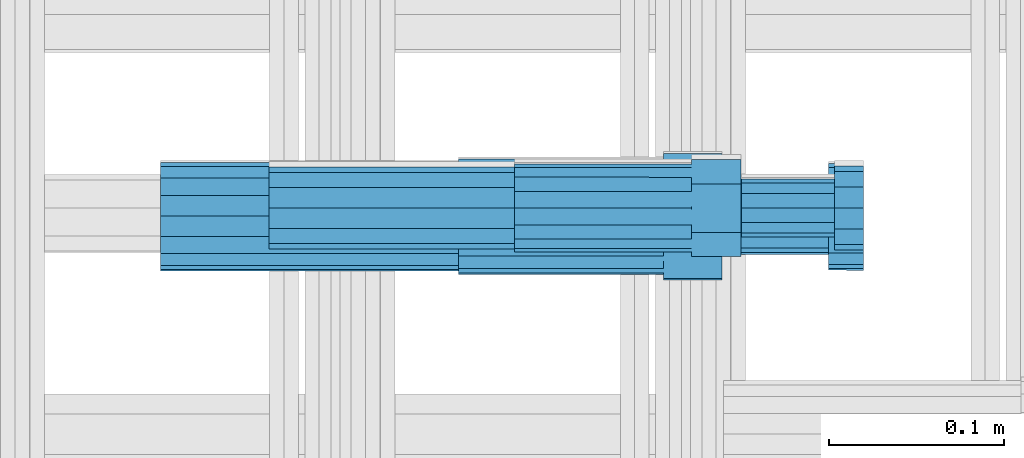
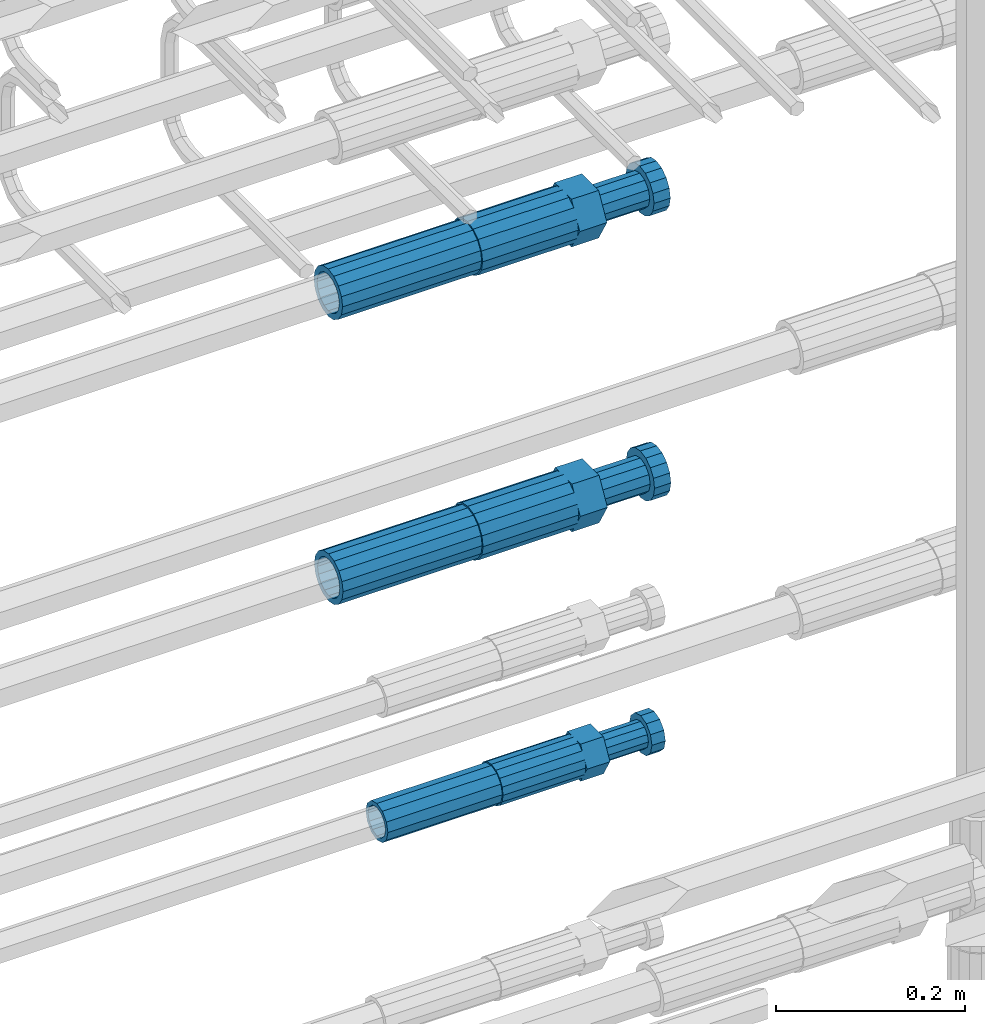
# One storey, part 49 of 177: 6 beams.
"""IFC2X3 building model written with IfcOpenShell, lengths in millimetres."""

from ifc_helpers import new_model, si_unit, frame, origin_with_axes, place, context, subcontext, project, spatial, faceted_brep, material, type_object, element, save


model = new_model("IFC2X3")

# Units and contexts
model_context_1 = context("Model", 3, precision=1e-05, world=origin_with_axes())
model_context_2 = context("Model", 3, precision=1e-05, world=origin_with_axes())
body_context = subcontext(model_context_2, "Body", "Model", "MODEL_VIEW")
ifc_project = project(units=[si_unit("LENGTHUNIT", "METRE", prefix="MILLI"), si_unit("AREAUNIT", "SQUARE_METRE"), si_unit("VOLUMEUNIT", "CUBIC_METRE"), si_unit("MASSUNIT", "GRAM", prefix="KILO"), si_unit("TIMEUNIT", "SECOND"), si_unit("PLANEANGLEUNIT", "RADIAN"), si_unit("SOLIDANGLEUNIT", "STERADIAN"), si_unit("THERMODYNAMICTEMPERATUREUNIT", "DEGREE_CELSIUS"), si_unit("LUMINOUSINTENSITYUNIT", "LUMEN")], contexts=[model_context_1])

# Site, building, storey
site_placement = place(None, origin_with_axes())
site = spatial("IfcSite", under=ifc_project, at=site_placement, CompositionType="ELEMENT")
building_placement = place(site_placement, origin_with_axes())
building = spatial("IfcBuilding", under=site, at=building_placement, Name="Undefined", CompositionType="ELEMENT")
storey_placement = place(building_placement, origin_with_axes())
storey = spatial("IfcBuildingStorey", under=building, at=storey_placement, Name="Undefined", CompositionType="ELEMENT", Elevation=0.0)

# Beams
ifc_material = material(Name="STEEL/S275")
beam_type_1 = type_object("IfcBeamType", PredefinedType="NOTDEFINED")
beam_1_placement = place(storey_placement, frame((2030819.00847314, 6206283.98588034, 19956.4868004557), z_axis=(0.0, 0.0, -1.0), x_axis=(1.0, 0.0, 0.0)))
element("IfcBeam", 1, at=beam_1_placement, inside=storey, type_object=beam_type_1, material=ifc_material, Name="AG40N", context=body_context, shape_type="Brep", body=[
    faceted_brep([(0.0, -23.5000000001164, -9.31322574615479e-10), (0.0, -21.7111690140155, 8.99306066054851), (170.0, -21.7111690140155, 8.99306066054851), (170.0, -23.5, 0.0), (0.0, -16.6170093578839, 16.6170093575493), (170.0, -16.6170093578839, 16.6170093575493), (0.0, -8.99306066057943, 21.7111690137535), (170.0, -8.99306066057943, 21.7111690137535), (0.0, 1.16415321826935e-10, 23.5), (170.0, 0.0, 23.5), (0.0, 8.99306066057943, 21.7111690137535), (170.0, 8.99306066057943, 21.7111690137535), (0.0, 16.6170093578839, 16.6170093575493), (170.0, 16.6170093578839, 16.6170093575493), (0.0, 21.7111690140155, 8.99306066054851), (170.0, 21.7111690140155, 8.99306066054851), (0.0, 23.5000000001164, -9.31322574615479e-10), (170.0, 23.5, 0.0), (0.0, 21.7111690140155, -8.99306066054851), (170.0, 21.7111690140155, -8.99306066054851), (0.0, 16.6170093578839, -16.6170093575493), (170.0, 16.6170093578839, -16.6170093575493), (0.0, 8.99306066057943, -21.7111690137535), (170.0, 8.99306066057943, -21.7111690137535), (0.0, 1.16415321826935e-10, -23.5000000009313), (170.0, 0.0, -23.5), (0.0, -8.99306066057943, -21.7111690137535), (170.0, -8.99306066057943, -21.7111690137535), (0.0, -16.6170093578839, -16.6170093575493), (170.0, -16.6170093578839, -16.6170093575493), (0.0, -21.7111690140155, -8.99306066054851), (170.0, -21.7111690140155, -8.99306066054851), (0.0, -30.5, 0.0), (0.0, -28.1783257415937, -11.6718446873128), (170.0, -28.1783257415937, -11.6718446873128), (170.0, -30.5, 0.0), (0.0, -21.5667568261888, -21.5667568258941), (170.0, -21.5667568261888, -21.5667568258941), (0.0, -11.6718446871346, -28.1783257415518), (170.0, -11.6718446871346, -28.1783257415518), (0.0, 0.0, -30.5), (170.0, 0.0, -30.5), (0.0, 11.6718446871346, -28.1783257415518), (170.0, 11.6718446871346, -28.1783257415518), (0.0, 21.5667568261888, -21.5667568258941), (170.0, 21.5667568261888, -21.5667568258941), (0.0, 28.1783257415937, -11.6718446873128), (170.0, 28.1783257415937, -11.6718446873128), (0.0, 30.5, 0.0), (170.0, 30.5, 0.0), (0.0, 28.1783257415937, 11.6718446873128), (170.0, 28.1783257415937, 11.6718446873128), (0.0, 21.5667568261888, 21.5667568258941), (170.0, 21.5667568261888, 21.5667568258941), (0.0, 11.6718446871346, 28.1783257415518), (170.0, 11.6718446871346, 28.1783257415518), (0.0, 0.0, 30.5), (170.0, 0.0, 30.5), (0.0, -11.6718446871346, 28.1783257415518), (170.0, -11.6718446871346, 28.1783257415518), (0.0, -21.5667568261888, 21.5667568258941), (170.0, -21.5667568261888, 21.5667568258941), (0.0, -28.1783257415937, 11.6718446873128), (170.0, -28.1783257415937, 11.6718446873128)], [[[0, 1, 2, 3]], [[1, 4, 5, 2]], [[4, 6, 7, 5]], [[6, 8, 9, 7]], [[8, 10, 11, 9]], [[10, 12, 13, 11]], [[12, 14, 15, 13]], [[14, 16, 17, 15]], [[16, 18, 19, 17]], [[18, 20, 21, 19]], [[20, 22, 23, 21]], [[22, 24, 25, 23]], [[24, 26, 27, 25]], [[26, 28, 29, 27]], [[28, 30, 31, 29]], [[30, 0, 3, 31]], [[32, 33, 34, 35]], [[33, 36, 37, 34]], [[36, 38, 39, 37]], [[38, 40, 41, 39]], [[40, 42, 43, 41]], [[42, 44, 45, 43]], [[44, 46, 47, 45]], [[46, 48, 49, 47]], [[48, 50, 51, 49]], [[50, 52, 53, 51]], [[52, 54, 55, 53]], [[54, 56, 57, 55]], [[56, 58, 59, 57]], [[58, 60, 61, 59]], [[60, 62, 63, 61]], [[62, 32, 35, 63]], [[37, 39, 41, 43, 45, 47, 49, 51, 53, 55, 57, 59, 61, 63, 35, 34], [5, 7, 9, 11, 13, 15, 17, 19, 21, 23, 25, 27, 29, 31, 3, 2]], [[62, 60, 58, 56, 54, 52, 50, 48, 46, 44, 42, 40, 38, 36, 33, 32], [30, 28, 26, 24, 22, 20, 18, 16, 14, 12, 10, 8, 6, 4, 1, 0]]]),
])
beam_2_placement = place(storey_placement, frame((2030819.00847313, 6206282.98588034, 19588.9891664317), z_axis=(0.0, 0.0, -1.0), x_axis=(1.0, 0.0, 0.0)))
element("IfcBeam", 2, at=beam_2_placement, inside=storey, type_object=beam_type_1, material=ifc_material, Name="AG40N", context=body_context, shape_type="Brep", body=[
    faceted_brep([(0.0, -23.5000000001164, -9.31322574615479e-10), (0.0, -21.7111690140155, 8.99306066054851), (170.0, -21.7111690140155, 8.99306066054851), (170.0, -23.5, 0.0), (0.0, -16.6170093578839, 16.6170093575493), (170.0, -16.6170093578839, 16.6170093575493), (0.0, -8.99306066057943, 21.7111690137535), (170.0, -8.99306066057943, 21.7111690137535), (0.0, 1.16415321826935e-10, 23.5), (170.0, 0.0, 23.5), (0.0, 8.99306066057943, 21.7111690137535), (170.0, 8.99306066057943, 21.7111690137535), (0.0, 16.6170093578839, 16.6170093575493), (170.0, 16.6170093578839, 16.6170093575493), (0.0, 21.7111690140155, 8.99306066054851), (170.0, 21.7111690140155, 8.99306066054851), (0.0, 23.5000000001164, -9.31322574615479e-10), (170.0, 23.5, 0.0), (0.0, 21.7111690140155, -8.99306066054851), (170.0, 21.7111690140155, -8.99306066054851), (0.0, 16.6170093578839, -16.6170093575493), (170.0, 16.6170093578839, -16.6170093575493), (0.0, 8.99306066057943, -21.7111690137535), (170.0, 8.99306066057943, -21.7111690137535), (0.0, 1.16415321826935e-10, -23.5000000009313), (170.0, 0.0, -23.5), (0.0, -8.99306066057943, -21.7111690137535), (170.0, -8.99306066057943, -21.7111690137535), (0.0, -16.6170093578839, -16.6170093575493), (170.0, -16.6170093578839, -16.6170093575493), (0.0, -21.7111690140155, -8.99306066054851), (170.0, -21.7111690140155, -8.99306066054851), (0.0, -30.5, 0.0), (0.0, -28.1783257415937, -11.6718446873128), (170.0, -28.1783257415937, -11.6718446873128), (170.0, -30.5, 0.0), (0.0, -21.5667568261888, -21.5667568258941), (170.0, -21.5667568261888, -21.5667568258941), (0.0, -11.6718446871346, -28.1783257415518), (170.0, -11.6718446871346, -28.1783257415518), (0.0, 0.0, -30.5), (170.0, 0.0, -30.5), (0.0, 11.6718446871346, -28.1783257415518), (170.0, 11.6718446871346, -28.1783257415518), (0.0, 21.5667568261888, -21.5667568258941), (170.0, 21.5667568261888, -21.5667568258941), (0.0, 28.1783257415937, -11.6718446873128), (170.0, 28.1783257415937, -11.6718446873128), (0.0, 30.5, 0.0), (170.0, 30.5, 0.0), (0.0, 28.1783257415937, 11.6718446873128), (170.0, 28.1783257415937, 11.6718446873128), (0.0, 21.5667568261888, 21.5667568258941), (170.0, 21.5667568261888, 21.5667568258941), (0.0, 11.6718446871346, 28.1783257415518), (170.0, 11.6718446871346, 28.1783257415518), (0.0, 0.0, 30.5), (170.0, 0.0, 30.5), (0.0, -11.6718446871346, 28.1783257415518), (170.0, -11.6718446871346, 28.1783257415518), (0.0, -21.5667568261888, 21.5667568258941), (170.0, -21.5667568261888, 21.5667568258941), (0.0, -28.1783257415937, 11.6718446873128), (170.0, -28.1783257415937, 11.6718446873128)], [[[0, 1, 2, 3]], [[1, 4, 5, 2]], [[4, 6, 7, 5]], [[6, 8, 9, 7]], [[8, 10, 11, 9]], [[10, 12, 13, 11]], [[12, 14, 15, 13]], [[14, 16, 17, 15]], [[16, 18, 19, 17]], [[18, 20, 21, 19]], [[20, 22, 23, 21]], [[22, 24, 25, 23]], [[24, 26, 27, 25]], [[26, 28, 29, 27]], [[28, 30, 31, 29]], [[30, 0, 3, 31]], [[32, 33, 34, 35]], [[33, 36, 37, 34]], [[36, 38, 39, 37]], [[38, 40, 41, 39]], [[40, 42, 43, 41]], [[42, 44, 45, 43]], [[44, 46, 47, 45]], [[46, 48, 49, 47]], [[48, 50, 51, 49]], [[50, 52, 53, 51]], [[52, 54, 55, 53]], [[54, 56, 57, 55]], [[56, 58, 59, 57]], [[58, 60, 61, 59]], [[60, 62, 63, 61]], [[62, 32, 35, 63]], [[37, 39, 41, 43, 45, 47, 49, 51, 53, 55, 57, 59, 61, 63, 35, 34], [5, 7, 9, 11, 13, 15, 17, 19, 21, 23, 25, 27, 29, 31, 3, 2]], [[62, 60, 58, 56, 54, 52, 50, 48, 46, 44, 42, 40, 38, 36, 33, 32], [30, 28, 26, 24, 22, 20, 18, 16, 14, 12, 10, 8, 6, 4, 1, 0]]]),
])
beam_type_2 = type_object("IfcBeamType", Name="ROD65", PredefinedType="NOTDEFINED")
beam_3_placement = place(storey_placement, frame((2030989.00847314, 6206283.98588034, 19956.4868004557), z_axis=(0.0, 0.0, -1.0), x_axis=(1.0, 0.0, 0.0)))
element("IfcBeam", 3, at=beam_3_placement, inside=storey, type_object=beam_type_2, material=ifc_material, Name="AGB40", ObjectType="ROD65", context=body_context, shape_type="Brep", body=[
    faceted_brep([(117.0, 8.17543110251427, 30.873805644922), (117.0, 17.8250000001863, 30.873805644922), (117.0, 22.0056958701462, 23.6326279877685), (117.0, 12.4372115517035, 30.0260848065373), (117.0, -17.8250000001863, 30.873805644922), (150.200000000186, -17.8250000001863, 30.873805644922), (150.200000000186, 17.8250000001863, 30.873805644922), (117.0, -8.17543110251427, 30.873805644922), (117.0, -12.4372115517035, 30.0260848065373), (117.0, -22.0056958701462, 23.6326279877685), (117.0, -35.6500000003725, 0.0), (150.200000000186, -35.6500000003725, 0.0), (117.0, -30.8443150008097, 8.32369058486074), (117.0, -32.5, 0.0), (117.0, -30.8443150008097, -8.32369058462791), (117.0, -17.8250000001863, -30.873805644922), (150.200000000186, -17.8250000001863, -30.873805644922), (117.0, -22.0056958701462, -23.6326279877685), (117.0, -12.4372115517035, -30.0260848065373), (117.0, -8.17543110251427, -30.873805644922), (117.0, 17.8250000001863, -30.873805644922), (150.200000000186, 17.8250000001863, -30.873805644922), (117.0, 8.17543110251427, -30.873805644922), (117.0, 22.0056958701462, -23.6326279877685), (117.0, 12.4372115517035, -30.0260848065373), (117.0, 35.6500000003725, 0.0), (150.200000000186, 35.6500000003725, 0.0), (117.0, 30.8443150008097, -8.32369058486074), (117.0, 30.8443150008097, 8.32369058462791), (117.0, 32.5, 0.0), (0.0, -22.9809703892097, 22.9809703885621), (0.0, -30.0260848058388, 12.4372115518636), (117.0, -30.0260848067701, 12.4372115519363), (117.0, -22.9809703882784, 22.9809703885112), (-2.3283064365387e-10, 22.9809703892097, -22.9809703885639), (-4.65661287307739e-10, 30.0260848077014, -12.4372115518672), (117.0, 30.0260848067701, -12.4372115519363), (117.0, 22.9809703882784, -22.9809703885112), (-2.3283064365387e-10, -30.0260848067701, -12.4372115518672), (-2.3283064365387e-10, -22.9809703892097, -22.9809703885621), (117.0, -22.9809703882784, -22.9809703885112), (117.0, -30.0260848067701, -12.4372115519363), (-2.3283064365387e-10, -12.4372115507722, 30.0260848066137), (-2.3283064365387e-10, 9.31322574615479e-10, 32.4999999999982), (-2.3283064365387e-10, 12.4372115526348, 30.0260848066137), (0.0, 22.9809703892097, 22.9809703885621), (-2.3283064365387e-10, 30.0260848077014, 12.4372115518636), (-2.3283064365387e-10, 32.5, 0.0), (-2.3283064365387e-10, 12.4372115526348, -30.0260848066173), (-2.3283064365387e-10, 9.31322574615479e-10, -32.5), (-2.3283064365387e-10, -12.4372115517035, -30.0260848066173), (-4.65661287307739e-10, -32.4999999990687, -1.81898940354586e-12), (117.0, 22.9809703882784, 22.9809703885112), (117.0, 30.0260848067701, 12.4372115519363), (117.0, 0.0, -32.5), (117.0, 0.0, 32.5), (150.200000000186, 10.5, -18.1865334794857), (150.200000000186, 0.0, -21.0), (150.200000000186, -10.5, -18.1865334794857), (150.200000000186, -18.18653347902, -10.5), (150.200000000186, -21.0, 0.0), (150.200000000186, -18.18653347902, 10.5), (150.200000000186, -10.5, 18.1865334794857), (150.200000000186, 0.0, 21.0), (150.200000000186, 10.5, 18.1865334794857), (150.200000000186, 18.18653347902, 10.5), (150.200000000186, 21.0, 0.0), (150.200000000186, 18.18653347902, -10.5), (210.980000000447, -18.18653347902, 10.5), (210.980000000447, -21.0, 0.0), (210.980000000447, -10.5, 18.1865334794857), (210.980000000447, 0.0, 21.0), (210.980000000447, 10.5, 18.1865334794857), (210.980000000447, 18.18653347902, 10.5), (210.980000000447, 21.0, 0.0), (210.980000000447, 18.18653347902, -10.5), (210.980000000447, 10.5, -18.1865334794857), (210.980000000447, 0.0, -21.0), (210.980000000447, -10.5, -18.1865334794857), (210.980000000447, -18.18653347902, -10.5), (211.001368442696, -27.7269937992096, -11.491116326768), (211.003082550167, -21.2238094303757, -21.223815418547), (231.002518367059, -21.2131944671273, -21.2132004550658), (231.000804259587, -27.7163788359612, -11.4805013632867), (211.001368440451, -11.4911085031927, -27.7269970395137), (231.000804257343, -11.4804935399443, -27.7163820760325), (210.996487071217, -0.0106065049767494, -30.0106107392348), (230.995922888109, 8.45827162265778e-06, -29.9999957757536), (210.989181586672, 11.46989420522, -27.7269970329944), (230.988617403564, 11.4805091684684, -27.7163820695132), (210.980564180623, 21.2025914648548, -21.2238154064398), (230.979999997515, 21.2132064281031, -21.2132004429586), (210.971946775022, 27.7057703435421, -11.4911163107026), (230.971382591913, 27.7163853067905, -11.4805013472214), (210.96464129175, 29.9893808094785, -0.0106149562634528), (230.964077108642, 29.9999957727268, 7.21774995326996e-09), (210.959759924415, 27.7057638689876, 11.4698863970116), (230.959195741307, 27.7163788322359, 11.4805013604928), (210.958045816944, 21.2025795001537, 21.2025854887906), (230.957481633835, 21.213194463402, 21.2132004522718), (210.95975992666, 11.4698785729706, 27.7057671097573), (230.959195743551, 11.480493536219, 27.7163820732385), (210.964641295894, -0.010623425245285, 29.9893808094785), (230.964077112785, -8.46199691295624e-06, 29.9999957729597), (210.971946780439, -11.4911241354421, 27.705767103238), (230.97138259733, -11.4805091721937, 27.7163820667192), (210.980564186488, -21.2238213950768, 21.2025854766835), (230.980000003379, -21.2132064318284, 21.2132004401647), (210.989181592089, -27.7270002737641, 11.4698863809463), (230.988617408981, -27.7163853105158, 11.4805013444275), (210.996487075361, -30.0106107397005, -0.0106149734929204), (230.995922892253, -29.9999957764521, -1.00117176771164e-08)], [[[0, 1, 2, 3]], [[4, 5, 6, 1, 0, 7]], [[4, 7, 8, 9]], [[10, 11, 5, 4, 9, 12]], [[10, 12, 13, 14]], [[15, 16, 11, 10, 14, 17]], [[15, 17, 18, 19]], [[20, 21, 16, 15, 19, 22]], [[23, 20, 22, 24]], [[25, 26, 21, 20, 23, 27]], [[28, 25, 27, 29]], [[30, 31, 32, 33]], [[34, 35, 36, 37]], [[38, 39, 40, 41]], [[31, 30, 42, 43, 44, 45, 46, 47, 35, 34, 48, 49, 50, 39, 38, 51]], [[46, 45, 52, 53]], [[29, 47, 46, 53, 28]], [[27, 36, 35, 47, 29]], [[23, 37, 36, 27]], [[24, 48, 34, 37, 23]], [[22, 54, 49, 48, 24]], [[19, 54, 22]], [[18, 50, 49, 54, 19]], [[17, 40, 39, 50, 18]], [[14, 41, 40, 17]], [[13, 51, 38, 41, 14]], [[12, 32, 31, 51, 13]], [[9, 33, 32, 12]], [[8, 42, 30, 33, 9]], [[7, 55, 43, 42, 8]], [[0, 55, 7]], [[3, 44, 43, 55, 0]], [[2, 52, 45, 44, 3]], [[28, 53, 52, 2]], [[1, 6, 26, 25, 28, 2]], [[5, 11, 16, 21, 26, 6], [56, 57, 58, 59, 60, 61, 62, 63, 64, 65, 66, 67]], [[68, 61, 60, 69]], [[70, 62, 61, 68]], [[71, 63, 62, 70]], [[72, 64, 63, 71]], [[73, 65, 64, 72]], [[74, 66, 65, 73]], [[75, 67, 66, 74]], [[76, 56, 67, 75]], [[77, 57, 56, 76]], [[78, 58, 57, 77]], [[79, 59, 58, 78]], [[69, 60, 59, 79]], [[80, 81, 82, 83]], [[81, 84, 85, 82]], [[84, 86, 87, 85]], [[86, 88, 89, 87]], [[88, 90, 91, 89]], [[90, 92, 93, 91]], [[92, 94, 95, 93]], [[94, 96, 97, 95]], [[96, 98, 99, 97]], [[98, 100, 101, 99]], [[100, 102, 103, 101]], [[102, 104, 105, 103]], [[104, 106, 107, 105]], [[106, 108, 109, 107]], [[108, 110, 111, 109]], [[82, 85, 87, 89, 91, 93, 95, 97, 99, 101, 103, 105, 107, 109, 111, 83]], [[110, 80, 83, 111]], [[108, 106, 104, 102, 100, 98, 96, 94, 92, 90, 88, 86, 84, 81, 80, 110], [75, 74, 73, 72, 71, 70, 68, 69, 79, 78, 77, 76]]]),
])
beam_4_placement = place(storey_placement, frame((2030989.00847313, 6206282.98588034, 19588.9891664317), z_axis=(0.0, 0.0, -1.0), x_axis=(1.0, 0.0, 0.0)))
element("IfcBeam", 4, at=beam_4_placement, inside=storey, type_object=beam_type_2, material=ifc_material, Name="AGB40", ObjectType="ROD65", context=body_context, shape_type="Brep", body=[
    faceted_brep([(117.0, 8.17543110251427, 30.873805644922), (117.0, 17.8250000001863, 30.873805644922), (117.0, 22.0056958701462, 23.6326279877685), (117.0, 12.4372115517035, 30.0260848065373), (117.0, -17.8250000001863, 30.873805644922), (150.200000000186, -17.8250000001863, 30.873805644922), (150.200000000186, 17.8250000001863, 30.873805644922), (117.0, -8.17543110251427, 30.873805644922), (117.0, -12.4372115517035, 30.0260848065373), (117.0, -22.0056958701462, 23.6326279877685), (117.0, -35.6500000003725, 0.0), (150.200000000186, -35.6500000003725, 0.0), (117.0, -30.8443150008097, 8.32369058486074), (117.0, -32.5, 0.0), (117.0, -30.8443150008097, -8.32369058462791), (117.0, -17.8250000001863, -30.873805644922), (150.200000000186, -17.8250000001863, -30.873805644922), (117.0, -22.0056958701462, -23.6326279877685), (117.0, -12.4372115517035, -30.0260848065373), (117.0, -8.17543110251427, -30.873805644922), (117.0, 17.8250000001863, -30.873805644922), (150.200000000186, 17.8250000001863, -30.873805644922), (117.0, 8.17543110251427, -30.873805644922), (117.0, 22.0056958701462, -23.6326279877685), (117.0, 12.4372115517035, -30.0260848065373), (117.0, 35.6500000003725, 0.0), (150.200000000186, 35.6500000003725, 0.0), (117.0, 30.8443150008097, -8.32369058486074), (117.0, 30.8443150008097, 8.32369058462791), (117.0, 32.5, 0.0), (0.0, -22.9809703892097, 22.9809703885621), (0.0, -30.0260848058388, 12.4372115518636), (117.0, -30.0260848067701, 12.4372115519363), (117.0, -22.9809703882784, 22.9809703885112), (-2.3283064365387e-10, 22.9809703892097, -22.9809703885639), (-4.65661287307739e-10, 30.0260848077014, -12.4372115518672), (117.0, 30.0260848067701, -12.4372115519363), (117.0, 22.9809703882784, -22.9809703885112), (-2.3283064365387e-10, -30.0260848067701, -12.4372115518672), (-2.3283064365387e-10, -22.9809703892097, -22.9809703885621), (117.0, -22.9809703882784, -22.9809703885112), (117.0, -30.0260848067701, -12.4372115519363), (-2.3283064365387e-10, -12.4372115507722, 30.0260848066137), (-2.3283064365387e-10, 9.31322574615479e-10, 32.4999999999982), (-2.3283064365387e-10, 12.4372115526348, 30.0260848066137), (0.0, 22.9809703892097, 22.9809703885621), (-2.3283064365387e-10, 30.0260848077014, 12.4372115518636), (-2.3283064365387e-10, 32.5, 0.0), (-2.3283064365387e-10, 12.4372115526348, -30.0260848066173), (-2.3283064365387e-10, 9.31322574615479e-10, -32.5), (-2.3283064365387e-10, -12.4372115517035, -30.0260848066173), (-4.65661287307739e-10, -32.4999999990687, -1.81898940354586e-12), (117.0, 22.9809703882784, 22.9809703885112), (117.0, 30.0260848067701, 12.4372115519363), (117.0, 0.0, -32.5), (117.0, 0.0, 32.5), (150.200000000186, 10.5, -18.1865334794857), (150.200000000186, 0.0, -21.0), (150.200000000186, -10.5, -18.1865334794857), (150.200000000186, -18.18653347902, -10.5), (150.200000000186, -21.0, 0.0), (150.200000000186, -18.18653347902, 10.5), (150.200000000186, -10.5, 18.1865334794857), (150.200000000186, 0.0, 21.0), (150.200000000186, 10.5, 18.1865334794857), (150.200000000186, 18.18653347902, 10.5), (150.200000000186, 21.0, 0.0), (150.200000000186, 18.18653347902, -10.5), (210.980000000447, -18.18653347902, 10.5), (210.980000000447, -21.0, 0.0), (210.980000000447, -10.5, 18.1865334794857), (210.980000000447, 0.0, 21.0), (210.980000000447, 10.5, 18.1865334794857), (210.980000000447, 18.18653347902, 10.5), (210.980000000447, 21.0, 0.0), (210.980000000447, 18.18653347902, -10.5), (210.980000000447, 10.5, -18.1865334794857), (210.980000000447, 0.0, -21.0), (210.980000000447, -10.5, -18.1865334794857), (210.980000000447, -18.18653347902, -10.5), (211.001368442696, -27.7269937992096, -11.491116326768), (211.003082550167, -21.2238094303757, -21.223815418547), (231.002518367059, -21.2131944671273, -21.2132004550658), (231.000804259587, -27.7163788359612, -11.4805013632867), (211.001368440451, -11.4911085031927, -27.7269970395137), (231.000804257343, -11.4804935399443, -27.7163820760325), (210.996487071217, -0.0106065049767494, -30.0106107392348), (230.995922888109, 8.45827162265778e-06, -29.9999957757536), (210.989181586672, 11.46989420522, -27.7269970329944), (230.988617403564, 11.4805091684684, -27.7163820695132), (210.980564180623, 21.2025914648548, -21.2238154064398), (230.979999997515, 21.2132064281031, -21.2132004429586), (210.971946775022, 27.7057703435421, -11.4911163107026), (230.971382591913, 27.7163853067905, -11.4805013472214), (210.96464129175, 29.9893808094785, -0.0106149562634528), (230.964077108642, 29.9999957727268, 7.21774995326996e-09), (210.959759924415, 27.7057638689876, 11.4698863970116), (230.959195741307, 27.7163788322359, 11.4805013604928), (210.958045816944, 21.2025795001537, 21.2025854887906), (230.957481633835, 21.213194463402, 21.2132004522718), (210.95975992666, 11.4698785729706, 27.7057671097573), (230.959195743551, 11.480493536219, 27.7163820732385), (210.964641295894, -0.010623425245285, 29.9893808094785), (230.964077112785, -8.46199691295624e-06, 29.9999957729597), (210.971946780439, -11.4911241354421, 27.705767103238), (230.97138259733, -11.4805091721937, 27.7163820667192), (210.980564186488, -21.2238213950768, 21.2025854766835), (230.980000003379, -21.2132064318284, 21.2132004401647), (210.989181592089, -27.7270002737641, 11.4698863809463), (230.988617408981, -27.7163853105158, 11.4805013444275), (210.996487075361, -30.0106107397005, -0.0106149734929204), (230.995922892253, -29.9999957764521, -1.00117176771164e-08)], [[[0, 1, 2, 3]], [[4, 5, 6, 1, 0, 7]], [[4, 7, 8, 9]], [[10, 11, 5, 4, 9, 12]], [[10, 12, 13, 14]], [[15, 16, 11, 10, 14, 17]], [[15, 17, 18, 19]], [[20, 21, 16, 15, 19, 22]], [[23, 20, 22, 24]], [[25, 26, 21, 20, 23, 27]], [[28, 25, 27, 29]], [[30, 31, 32, 33]], [[34, 35, 36, 37]], [[38, 39, 40, 41]], [[31, 30, 42, 43, 44, 45, 46, 47, 35, 34, 48, 49, 50, 39, 38, 51]], [[46, 45, 52, 53]], [[29, 47, 46, 53, 28]], [[27, 36, 35, 47, 29]], [[23, 37, 36, 27]], [[24, 48, 34, 37, 23]], [[22, 54, 49, 48, 24]], [[19, 54, 22]], [[18, 50, 49, 54, 19]], [[17, 40, 39, 50, 18]], [[14, 41, 40, 17]], [[13, 51, 38, 41, 14]], [[12, 32, 31, 51, 13]], [[9, 33, 32, 12]], [[8, 42, 30, 33, 9]], [[7, 55, 43, 42, 8]], [[0, 55, 7]], [[3, 44, 43, 55, 0]], [[2, 52, 45, 44, 3]], [[28, 53, 52, 2]], [[1, 6, 26, 25, 28, 2]], [[5, 11, 16, 21, 26, 6], [56, 57, 58, 59, 60, 61, 62, 63, 64, 65, 66, 67]], [[68, 61, 60, 69]], [[70, 62, 61, 68]], [[71, 63, 62, 70]], [[72, 64, 63, 71]], [[73, 65, 64, 72]], [[74, 66, 65, 73]], [[75, 67, 66, 74]], [[76, 56, 67, 75]], [[77, 57, 56, 76]], [[78, 58, 57, 77]], [[79, 59, 58, 78]], [[69, 60, 59, 79]], [[80, 81, 82, 83]], [[81, 84, 85, 82]], [[84, 86, 87, 85]], [[86, 88, 89, 87]], [[88, 90, 91, 89]], [[90, 92, 93, 91]], [[92, 94, 95, 93]], [[94, 96, 97, 95]], [[96, 98, 99, 97]], [[98, 100, 101, 99]], [[100, 102, 103, 101]], [[102, 104, 105, 103]], [[104, 106, 107, 105]], [[106, 108, 109, 107]], [[108, 110, 111, 109]], [[82, 85, 87, 89, 91, 93, 95, 97, 99, 101, 103, 105, 107, 109, 111, 83]], [[110, 80, 83, 111]], [[108, 106, 104, 102, 100, 98, 96, 94, 92, 90, 88, 86, 84, 81, 80, 110], [75, 74, 73, 72, 71, 70, 68, 69, 79, 78, 77, 76]]]),
])
beam_type_3 = type_object("IfcBeamType", PredefinedType="NOTDEFINED")
beam_5_placement = place(storey_placement, frame((2030880.99847313, 6206288.48588035, 19248.4868004347), z_axis=(0.0, 0.0, -1.0), x_axis=(1.0, 0.0, 0.0)))
element("IfcBeam", 5, at=beam_5_placement, inside=storey, type_object=beam_type_3, material=ifc_material, Name="AG32N", context=body_context, shape_type="Brep", body=[
    faceted_brep([(0.0, -18.4999999998836, -9.31322574615479e-10), (7.0839612702856e-11, -16.0214699700121, 9.25), (140.0, -16.0214699698845, 9.24999999906868), (140.0, -18.4999999998836, -9.31322574615479e-10), (0.0, -9.24999999988358, 16.0214699683711), (140.0, -9.24999999988358, 16.0214699683711), (9.69157554209232e-11, 0.0, 18.5), (140.0, -1.16415321826935e-10, 18.4999999981374), (0.0, 9.24999999988358, 16.0214699683711), (140.0, 9.24999999988358, 16.0214699683711), (2.60761427180671e-11, 16.0214699700121, 9.24999999999999), (140.0, 16.0214699698845, 9.24999999906868), (0.0, 18.5000000001164, -9.31322574615479e-10), (140.0, 18.5000000001164, -9.31322574615479e-10), (-7.0839612702856e-11, 16.0214699700121, -9.25000000000001), (140.0, 16.0214699701173, -9.25000000093132), (0.0, 9.25000000011642, -16.0214699711651), (140.0, 9.25000000011642, -16.0214699711651), (-9.69157554209232e-11, -7.18869408444789e-15, -18.5), (140.0, -1.16415321826935e-10, -18.5000000009313), (0.0, -9.25000000011642, -16.0214699702337), (140.0, -9.25000000011642, -16.0214699702337), (-2.60761427180672e-11, -16.0214699700121, -9.25), (140.0, -16.0214699701173, -9.25000000093132), (0.0, -23.5000000001164, -9.31322574615479e-10), (0.0, -20.3515969890868, -11.75), (140.0, -20.3515969890868, -11.75), (140.0, -23.5000000001164, -9.31322574615479e-10), (0.0, -11.7500000001164, -20.3515969896689), (140.0, -11.7500000001164, -20.3515969896689), (0.0, 1.16415321826935e-10, -23.5000000009313), (140.0, 1.16415321826935e-10, -23.5000000009313), (0.0, 11.7500000001164, -20.3515969896689), (140.0, 11.7500000001164, -20.3515969896689), (0.0, 20.3515969890868, -11.7500000009313), (140.0, 20.3515969890868, -11.7500000009313), (0.0, 23.5000000001164, -9.31322574615479e-10), (140.0, 23.5000000001164, -9.31322574615479e-10), (0.0, 20.351596988854, 11.7499999990687), (140.0, 20.351596988854, 11.7499999990687), (0.0, 11.7499999998836, 20.3515969878063), (140.0, 11.7499999998836, 20.3515969878063), (0.0, 1.16415321826935e-10, 23.5), (140.0, 1.16415321826935e-10, 23.5), (0.0, -11.7499999998836, 20.3515969887376), (140.0, -11.7499999998836, 20.3515969887376), (0.0, -20.3515969893197, 11.7499999981374), (140.0, -20.3515969893197, 11.7499999981374)], [[[0, 1, 2, 3]], [[1, 4, 5, 2]], [[4, 6, 7, 5]], [[6, 8, 9, 7]], [[8, 10, 11, 9]], [[10, 12, 13, 11]], [[12, 14, 15, 13]], [[14, 16, 17, 15]], [[16, 18, 19, 17]], [[18, 20, 21, 19]], [[20, 22, 23, 21]], [[22, 0, 3, 23]], [[24, 25, 26, 27]], [[25, 28, 29, 26]], [[28, 30, 31, 29]], [[30, 32, 33, 31]], [[32, 34, 35, 33]], [[34, 36, 37, 35]], [[36, 38, 39, 37]], [[38, 40, 41, 39]], [[40, 42, 43, 41]], [[42, 44, 45, 43]], [[44, 46, 47, 45]], [[46, 24, 27, 47]], [[29, 31, 33, 35, 37, 39, 41, 43, 45, 47, 27, 26], [5, 7, 9, 11, 13, 15, 17, 19, 21, 23, 3, 2]], [[46, 44, 42, 40, 38, 36, 34, 32, 30, 28, 25, 24], [22, 20, 18, 16, 14, 12, 10, 8, 6, 4, 1, 0]]]),
])
beam_type_4 = type_object("IfcBeamType", Name="ROD50", PredefinedType="NOTDEFINED")
beam_6_placement = place(storey_placement, frame((2031020.99847313, 6206288.48588035, 19248.4868004347), z_axis=(0.0, 0.0, -1.0), x_axis=(1.0, 0.0, 0.0)))
element("IfcBeam", 6, at=beam_6_placement, inside=storey, type_object=beam_type_4, material=ifc_material, Name="AGB32", ObjectType="ROD50", context=body_context, shape_type="Brep", body=[
    faceted_brep([(129.100000000559, -13.8425000002608, 23.9759132992476), (129.100000000559, -27.6850000005215, -4.65661287307739e-09), (129.100000000559, -13.8424999993294, -23.9759133085608), (129.100000000559, 13.8425000002608, -23.975913308328), (129.100000000559, 27.6849999995902, -4.42378222942352e-09), (129.100000000559, 13.8424999993294, 23.9759132992476), (101.0, -13.8424999993294, -23.9759133085608), (101.0, -27.6850000005215, -4.65661287307739e-09), (101.0, -23.5887256413698, -7.09495531534776), (101.0, -17.528511938639, -17.5915533546358), (101.0, -9.56708580814302, -23.0969883131329), (101.0, -5.14843146782368, -23.975913308328), (101.0, 13.8425000002608, -23.975913308328), (101.0, 5.14843147061765, -23.975913308328), (101.0, 9.56708581000566, -23.0969883129001), (101.0, 17.5285119377077, -17.5915533537045), (101.0, 27.6849999995902, -4.42378222942352e-09), (101.0, 23.5887256432325, -7.09495531162247), (101.0, 25.0000000009313, -2.3283064365387e-10), (101.0, 23.5887256460264, 7.09495529648848), (101.0, 13.8424999993294, 23.9759132992476), (101.0, 17.5285119339824, 17.5915533511434), (101.0, 5.14843151345849, 23.9759132992476), (101.0, 9.56708581000566, 23.0969883126672), (101.0, -13.8425000002608, 23.9759132992476), (101.0, -5.14843151252717, 23.9759132990148), (101.0, -17.5285119339824, 17.5915533518419), (101.0, -9.56708580814302, 23.0969883126672), (101.0, -23.5887256441638, 7.09495530254208), (101.0, -24.9999999990687, -2.3283064365387e-10), (101.0, -23.0969883119687, 9.56708580884151), (0.0, -23.0969883129001, 9.56708580912709), (0.0, -25.0, 0.0), (0.0, -17.6776695298031, 17.677669529663), (0.0, -9.56708580907434, 23.0969883127818), (101.0, 9.31322574615479e-10, 24.9999999997672), (0.0, 0.0, 25.0), (0.0, 9.56708580907434, 23.0969883127818), (0.0, 17.6776695298031, 17.677669529663), (0.0, 23.0969883129001, 9.56708580912709), (101.0, 23.0969883138314, 9.56708580884151), (0.0, 25.0, 0.0), (101.0, 23.0969883138314, -9.56708580930717), (0.0, 23.0969883129001, -9.56708580912709), (0.0, 17.6776695298031, -17.677669529663), (0.0, 9.56708580907434, -23.0969883127818), (101.0, 0.0, -25.0), (0.0, 0.0, -25.0), (0.0, -9.56708580907434, -23.0969883127818), (0.0, -17.6776695298031, -17.677669529663), (0.0, -23.0969883129001, -9.56708580912709), (101.0, -23.0969883119687, -9.56708580930717), (129.5, -14.2894191620871, 8.24999999511056), (129.5, -8.25, 14.2894191578962), (129.5, 0.0, 16.4999999953434), (129.5, 8.25, 14.2894191576634), (129.5, 14.2894191620871, 8.24999999557622), (129.5, 16.5, -4.65661287307739e-09), (129.5, 14.2894191620871, -8.25000000465661), (129.5, 8.25, -14.2894191672094), (129.5, 0.0, -16.5000000046566), (129.5, -8.25000000093132, -14.2894191669766), (129.5, -14.2894191630185, -8.25000000465661), (129.5, -16.5, -4.65661287307739e-09), (182.500000000466, -14.2894191620871, 8.24999999511056), (182.500000000466, -16.5, -4.65661287307739e-09), (182.500000000466, -8.25, 14.2894191578962), (182.500000000466, 0.0, 16.4999999953434), (182.500000000466, 8.25, 14.2894191576634), (182.500000000466, 14.2894191620871, 8.24999999557622), (182.500000000466, 16.5, -4.65661287307739e-09), (182.500000000466, 14.2894191620871, -8.25000000465661), (182.500000000466, 8.25, -14.2894191672094), (182.500000000466, 0.0, -16.5000000046566), (182.500000000466, -8.25000000093132, -14.2894191669766), (182.500000000466, -14.2894191630185, -8.25000000465661), (182.5, -20.7846096921712, -12.0000000044238), (182.5, -12.0, -20.7846096954308), (199.0, -12.0, -20.7846096954308), (199.0, -20.7846096921712, -12.0000000044238), (182.5, -9.31322574615479e-10, -24.0000000044238), (199.0, -9.31322574615479e-10, -24.0000000044238), (182.5, 12.0, -20.7846096956637), (199.0, 12.0, -20.7846096956637), (182.5, 20.7846096912399, -12.0000000046566), (199.0, 20.7846096912399, -12.0000000046566), (182.5, 24.0, -4.65661287307739e-09), (199.0, 24.0, -4.65661287307739e-09), (182.5, 20.7846096912399, 11.9999999953434), (199.0, 20.7846096912399, 11.9999999953434), (182.5, 12.0, 20.7846096863504), (199.0, 12.0, 20.7846096863504), (182.5, -9.31322574615479e-10, 23.9999999953434), (199.0, -9.31322574615479e-10, 23.9999999953434), (182.5, -12.0000000009313, 20.7846096861176), (199.0, -12.0000000009313, 20.7846096861176), (182.5, -20.7846096912399, 11.9999999955762), (199.0, -20.7846096912399, 11.9999999955762), (182.5, -24.0, -4.65661287307739e-09), (199.0, -24.0, -4.65661287307739e-09)], [[[0, 1, 2, 3, 4, 5]], [[6, 2, 1, 7, 8, 9]], [[6, 9, 10, 11]], [[12, 3, 2, 6, 11, 13]], [[12, 13, 14, 15]], [[16, 4, 3, 12, 15, 17]], [[16, 17, 18, 19]], [[20, 5, 4, 16, 19, 21]], [[22, 20, 21, 23]], [[24, 0, 5, 20, 22, 25]], [[26, 24, 25, 27]], [[7, 1, 0, 24, 26, 28]], [[7, 28, 29, 8]], [[28, 30, 31, 32, 29]], [[26, 30, 28]], [[33, 31, 30, 26]], [[27, 34, 33, 26]], [[25, 35, 36, 34, 27]], [[22, 35, 25]], [[23, 37, 36, 35, 22]], [[21, 38, 37, 23]], [[39, 38, 21, 40]], [[19, 40, 21]], [[18, 41, 39, 40, 19]], [[17, 42, 43, 41, 18]], [[15, 42, 17]], [[44, 43, 42, 15]], [[14, 45, 44, 15]], [[13, 46, 47, 45, 14]], [[11, 46, 13]], [[10, 48, 47, 46, 11]], [[9, 49, 48, 10]], [[50, 49, 9, 51]], [[8, 51, 9]], [[29, 32, 50, 51, 8]], [[31, 33, 34, 36, 37, 38, 39, 41, 43, 44, 45, 47, 48, 49, 50, 32]], [[52, 53, 54, 55, 56, 57, 58, 59, 60, 61, 62, 63]], [[64, 52, 63, 65]], [[66, 53, 52, 64]], [[67, 54, 53, 66]], [[68, 55, 54, 67]], [[69, 56, 55, 68]], [[70, 57, 56, 69]], [[71, 58, 57, 70]], [[72, 59, 58, 71]], [[73, 60, 59, 72]], [[74, 61, 60, 73]], [[75, 62, 61, 74]], [[65, 63, 62, 75]], [[76, 77, 78, 79]], [[77, 80, 81, 78]], [[80, 82, 83, 81]], [[82, 84, 85, 83]], [[84, 86, 87, 85]], [[86, 88, 89, 87]], [[88, 90, 91, 89]], [[90, 92, 93, 91]], [[92, 94, 95, 93]], [[94, 96, 97, 95]], [[96, 98, 99, 97]], [[78, 81, 83, 85, 87, 89, 91, 93, 95, 97, 99, 79]], [[98, 76, 79, 99]], [[96, 94, 92, 90, 88, 86, 84, 82, 80, 77, 76, 98], [68, 67, 66, 64, 65, 75, 74, 73, 72, 71, 70, 69]]]),
])

save(model, "model.ifc")
